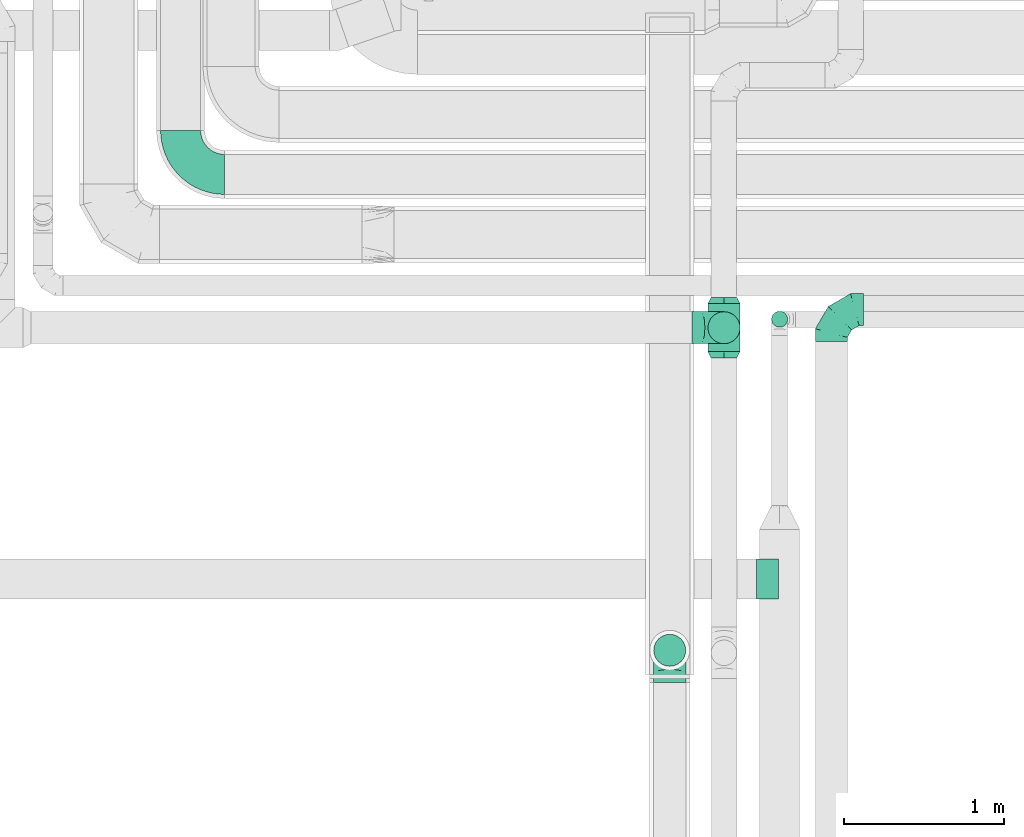
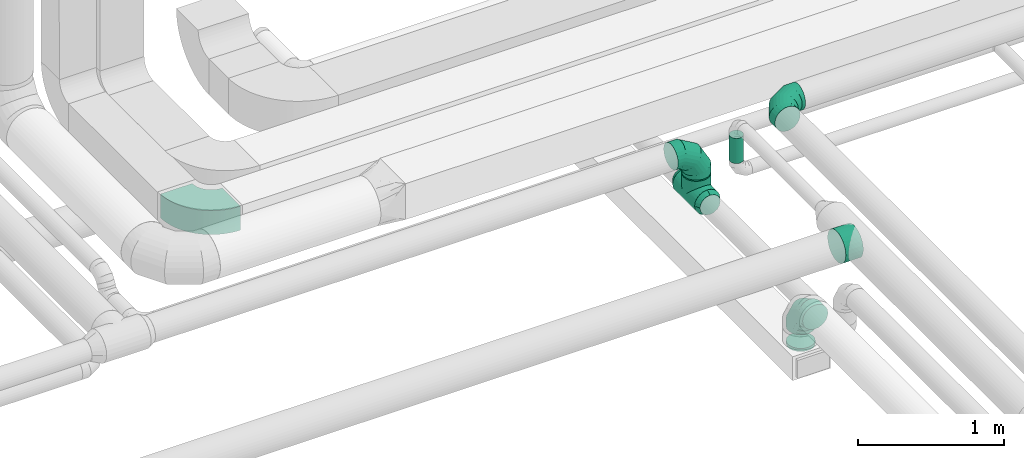
# One storey, part 38 of 92: 9 flow fittings, 2 flow segments.
"""IFC2X3 building model written with IfcOpenShell, lengths in millimetres."""

from ifc_helpers import new_model, entity, si_unit, converted_unit, derived_unit, direction, frame, frame_2d, origin, origin_2d_with_axis, place, context, subcontext, project, spatial, polyline, circle_curve, parameter, trimmed, segment, composite_curve, circle, outline, extrude, faceted_brep, source, transform, mapped, material, type_object, type_shapes, element, save


model = new_model("IFC2X3")

# Units and contexts
model_context = context("Model", 3, precision=0.01, world=origin(), true_north=direction((6.12303176911189e-17, 1.0)))
body_context = subcontext(model_context, "Body", "Model", "MODEL_VIEW")
ifc_project = project(units=[si_unit("LENGTHUNIT", "METRE", prefix="MILLI"), si_unit("AREAUNIT", "SQUARE_METRE"), si_unit("VOLUMEUNIT", "CUBIC_METRE"), converted_unit("PLANEANGLEUNIT", "DEGREE", entity("IfcRatioMeasure", 0.0174532925199433), si_unit("PLANEANGLEUNIT", "RADIAN"), dimensions=[0, 0, 0, 0, 0, 0, 0]), si_unit("MASSUNIT", "GRAM", prefix="KILO"), derived_unit("MASSDENSITYUNIT", [(si_unit("MASSUNIT", "GRAM", prefix="KILO"), 1), (si_unit("LENGTHUNIT", "METRE"), -3)]), derived_unit("MOMENTOFINERTIAUNIT", [(si_unit("LENGTHUNIT", "METRE"), 4)]), si_unit("TIMEUNIT", "SECOND"), si_unit("FREQUENCYUNIT", "HERTZ"), si_unit("THERMODYNAMICTEMPERATUREUNIT", "DEGREE_CELSIUS"), derived_unit("THERMALTRANSMITTANCEUNIT", [(si_unit("MASSUNIT", "GRAM", prefix="KILO"), 1), (si_unit("THERMODYNAMICTEMPERATUREUNIT", "KELVIN"), -1), (si_unit("TIMEUNIT", "SECOND"), -3)]), derived_unit("VOLUMETRICFLOWRATEUNIT", [(si_unit("LENGTHUNIT", "METRE"), 3), (si_unit("TIMEUNIT", "SECOND"), -1)]), derived_unit("MASSFLOWRATEUNIT", [(si_unit("MASSUNIT", "GRAM", prefix="KILO"), 1), (si_unit("TIMEUNIT", "SECOND"), -1)]), derived_unit("ROTATIONALFREQUENCYUNIT", [(si_unit("TIMEUNIT", "SECOND"), -1)]), si_unit("ELECTRICCURRENTUNIT", "AMPERE"), si_unit("ELECTRICVOLTAGEUNIT", "VOLT"), si_unit("POWERUNIT", "WATT"), si_unit("FORCEUNIT", "NEWTON", prefix="KILO"), si_unit("ILLUMINANCEUNIT", "LUX"), si_unit("LUMINOUSFLUXUNIT", "LUMEN"), si_unit("LUMINOUSINTENSITYUNIT", "CANDELA"), derived_unit("USERDEFINED", [(si_unit("MASSUNIT", "GRAM", prefix="KILO"), -1), (si_unit("LENGTHUNIT", "METRE"), -2), (si_unit("TIMEUNIT", "SECOND"), 3), (si_unit("LUMINOUSFLUXUNIT", "LUMEN"), 1)]), derived_unit("LINEARVELOCITYUNIT", [(si_unit("LENGTHUNIT", "METRE"), 1), (si_unit("TIMEUNIT", "SECOND"), -1)]), si_unit("PRESSUREUNIT", "PASCAL"), derived_unit("USERDEFINED", [(si_unit("LENGTHUNIT", "METRE"), -2), (si_unit("MASSUNIT", "GRAM", prefix="KILO"), 1), (si_unit("TIMEUNIT", "SECOND"), -2)]), derived_unit("LINEARFORCEUNIT", [(si_unit("MASSUNIT", "GRAM", prefix="KILO"), 1), (si_unit("LENGTHUNIT", "METRE"), 1), (si_unit("TIMEUNIT", "SECOND"), -2), (si_unit("LENGTHUNIT", "METRE"), -1)]), derived_unit("PLANARFORCEUNIT", [(si_unit("MASSUNIT", "GRAM", prefix="KILO"), 1), (si_unit("LENGTHUNIT", "METRE"), 1), (si_unit("TIMEUNIT", "SECOND"), -2), (si_unit("LENGTHUNIT", "METRE"), -2)])], contexts=[model_context])

# Site, building, storey
site_placement = place(None, origin())
site = spatial("IfcSite", under=ifc_project, at=site_placement, CompositionType="ELEMENT")
building_placement = place(site_placement, origin())
building = spatial("IfcBuilding", under=site, at=building_placement, CompositionType="ELEMENT")
storey_placement = place(building_placement, frame((0.0, 0.0, 4200.0)))
storey = spatial("IfcBuildingStorey", under=building, at=storey_placement, CompositionType="ELEMENT", Elevation=4200.0)

# Flow segments
duct_segment_type_1 = type_object("IfcDuctSegmentType", PredefinedType="NOTDEFINED")
flow_segment_1_placement = place(storey_placement, frame((12738.9, 11238.35, 3050.0)))
element("IfcFlowSegment", 1, at=flow_segment_1_placement, inside=storey, type_object=duct_segment_type_1, context=body_context, shape_type="SweptSolid", body=[
    extrude(circle(Radius=50.0, at=origin_2d_with_axis()), frame((51.6, 51.6, 0.0), z_axis=(0.0, 0.0, 1.0), x_axis=(-1.0, 0.0, 0.0)), (0.0, 0.0, 1.0), 210.000000000015),
])
duct_segment_type_2 = type_object("IfcDuctSegmentType", PredefinedType="NOTDEFINED")
flow_segment_2_placement = place(storey_placement, frame((12341.42, 11135.6, 3090.0)))
element("IfcFlowSegment", 2, at=flow_segment_2_placement, inside=storey, type_object=duct_segment_type_2, context=body_context, shape_type="SweptSolid", body=[
    extrude(circle(Radius=100.0, at=origin_2d_with_axis()), frame((101.6, 101.6, 0.0), z_axis=(0.0, 0.0, 1.0), x_axis=(0.0, 1.0, 0.0)), (0.0, 0.0, 1.0), 10.0000000000248),
])

# Flow fittings
ifc_material = material()
duct_fitting_type_1 = type_object("IfcDuctFittingType", PredefinedType="NOTDEFINED", material=ifc_material)
shared_shape_1 = source(origin(), body_context, "Body", "Brep", [
    faceted_brep([(40.0, -58.78, -80.9), (40.0, -30.9, -95.11), (40.0, 0.0, -100.0), (40.0, 30.9, -95.11), (40.0, 58.78, -80.9), (40.0, 80.9, -58.78), (40.0, 95.11, -30.9), (40.0, 100.0, 0.0), (40.0, 95.11, 30.9), (40.0, 80.9, 58.78), (40.0, 58.78, 80.9), (40.0, 30.9, 95.11), (40.0, 0.0, 100.0), (40.0, -30.9, 95.11), (40.0, -58.78, 80.9), (40.0, -80.9, 58.78), (40.0, -95.11, 30.9), (40.0, -100.0, 0.0), (40.0, -95.11, -30.9), (40.0, -80.9, -58.78), (0.0, -30.61, -73.91), (0.0, -43.59, -65.24), (0.0, -56.57, -56.57), (0.0, -65.24, -43.59), (0.0, -73.91, -30.61), (0.0, -76.96, -15.31), (0.0, -80.0, 0.0), (0.0, -76.96, 15.31), (0.0, -73.91, 30.61), (0.0, -65.24, 43.59), (0.0, -56.57, 56.57), (0.0, -43.59, 65.24), (0.0, -30.61, 73.91), (0.0, -15.31, 76.96), (0.0, 0.0, 80.0), (0.0, 15.31, 76.96), (0.0, 30.61, 73.91), (0.0, 43.59, 65.24), (0.0, 56.57, 56.57), (0.0, 65.24, 43.59), (0.0, 73.91, 30.61), (0.0, 76.96, 15.31), (0.0, 80.0, 0.0), (0.0, 76.96, -15.31), (0.0, 73.91, -30.61), (0.0, 65.24, -43.59), (0.0, 56.57, -56.57), (0.0, 43.59, -65.24), (0.0, 30.61, -73.91), (0.0, 15.31, -76.96), (0.0, 0.0, -80.0), (0.0, -15.31, -76.96)], [[[0, 1, 2, 3, 4, 5, 6, 7, 8, 9, 10, 11, 12, 13, 14, 15, 16, 17, 18, 19]], [[20, 21, 22, 23, 24, 25, 26, 27, 28, 29, 30, 31, 32, 33, 34, 35, 36, 37, 38, 39, 40, 41, 42, 43, 44, 45, 46, 47, 48, 49, 50, 51]], [[7, 41, 8]], [[40, 9, 8]], [[10, 38, 37, 36]], [[39, 38, 9, 40]], [[11, 36, 35]], [[34, 12, 35]], [[41, 40, 8]], [[10, 36, 11]], [[35, 12, 11]], [[41, 7, 42]], [[38, 10, 9]], [[12, 33, 13]], [[32, 14, 13]], [[15, 30, 29, 28]], [[31, 30, 14, 32]], [[16, 28, 27]], [[26, 17, 27]], [[33, 32, 13]], [[15, 28, 16]], [[27, 17, 16]], [[33, 12, 34]], [[30, 15, 14]], [[17, 25, 18]], [[24, 19, 18]], [[0, 22, 21, 20]], [[23, 22, 19, 24]], [[1, 20, 51]], [[50, 2, 51]], [[25, 24, 18]], [[0, 20, 1]], [[51, 2, 1]], [[25, 17, 26]], [[22, 0, 19]], [[2, 49, 3]], [[48, 4, 3]], [[5, 46, 45, 44]], [[47, 46, 4, 48]], [[6, 44, 43]], [[42, 7, 43]], [[49, 48, 3]], [[5, 44, 6]], [[43, 7, 6]], [[49, 2, 50]], [[46, 5, 4]]]),
])
type_shapes(duct_fitting_type_1, [shared_shape_1])
for number, where, z_axis, x_axis in (
    (3, (12443.02, 11427.19, 2940.0), (0.0, 0.0, 1.0), (0.0, -1.0, 0.0)),
    (4, (12443.02, 11047.19, 2940.0), (0.0, 0.0, 1.0), (0.0, 1.0, 0.0)),
):
    element("IfcFlowFitting", number, at=place(storey_placement, frame(where, z_axis=z_axis, x_axis=x_axis)), inside=storey, type_object=duct_fitting_type_1, material=ifc_material, context=body_context, shape_type="MappedRepresentation", body=[
        mapped(shared_shape_1, transform((0.0, 0.0, 0.0), scale=1.0)),
    ])
duct_fitting_type_2 = type_object("IfcDuctFittingType", PredefinedType="NOTDEFINED", material=ifc_material)
shared_shape_2 = source(origin(), body_context, "Body", "Brep", [
    faceted_brep([(-200.0, 0.0, -100.0), (-200.0, -25.88, -96.59), (-200.0, -50.0, -86.6), (-200.0, -70.71, -70.71), (-200.0, -86.6, -50.0), (-200.0, -96.59, -25.88), (-200.0, -100.0, 0.0), (-200.0, -96.59, 25.88), (-200.0, -86.6, 50.0), (-200.0, -70.71, 70.71), (-200.0, -50.0, 86.6), (-200.0, -25.88, 96.59), (-200.0, 0.0, 100.0), (-200.0, 25.88, 96.59), (-200.0, 50.0, 86.6), (-200.0, 70.71, 70.71), (-200.0, 86.6, 50.0), (-200.0, 96.59, 25.88), (-200.0, 100.0, 0.0), (-200.0, 96.59, -25.88), (-200.0, 86.6, -50.0), (-200.0, 70.71, -70.71), (-200.0, 50.0, -86.6), (-200.0, 25.88, -96.59), (-153.35, 25.88, 96.59), (-159.81, 50.0, 86.6), (-146.41, 0.0, 100.0), (-165.36, 70.71, 70.71), (-172.29, 96.59, 25.88), (-173.21, 100.0, 0.0), (-169.62, 86.6, 50.0), (-169.62, 86.6, -50.0), (-165.36, 70.71, -70.71), (-172.29, 96.59, -25.88), (-153.35, 25.88, -96.59), (-146.41, 0.0, -100.0), (-159.81, 50.0, -86.6), (-139.48, -25.88, -96.59), (-133.01, -50.0, -86.6), (-127.46, -70.71, -70.71), (-123.21, -86.6, -50.0), (-120.53, -96.59, -25.88), (-119.62, -100.0, 0.0), (-120.53, -96.59, 25.88), (-123.21, -86.6, 50.0), (-127.46, -70.71, 70.71), (-133.01, -50.0, 86.6), (-139.48, -25.88, 96.59), (-72.54, 72.54, 96.59), (-90.19, 90.19, 86.6), (-53.59, 53.59, 100.0), (-105.35, 105.35, 70.71), (-116.99, 116.99, 50.0), (-124.3, 124.3, 25.88), (-126.79, 126.79, 0.0), (-124.3, 124.3, -25.88), (-116.99, 116.99, -50.0), (-105.35, 105.35, -70.71), (-72.54, 72.54, -96.59), (-53.59, 53.59, -100.0), (-90.19, 90.19, -86.6), (-34.64, 34.64, -96.59), (-16.99, 16.99, -86.6), (-1.83, 1.83, -70.71), (9.81, -9.81, -50.0), (17.12, -17.12, -25.88), (19.62, -19.62, 0.0), (17.12, -17.12, 25.88), (9.81, -9.81, 50.0), (-1.83, 1.83, 70.71), (-16.99, 16.99, 86.6), (-34.64, 34.64, 96.59), (-25.88, 153.35, 96.59), (-50.0, 159.81, 86.6), (0.0, 146.41, 100.0), (-70.71, 165.36, 70.71), (-86.6, 169.62, 50.0), (-96.59, 172.29, 25.88), (-100.0, 173.21, 0.0), (-96.59, 172.29, -25.88), (-86.6, 169.62, -50.0), (-70.71, 165.36, -70.71), (-25.88, 153.35, -96.59), (0.0, 146.41, -100.0), (-50.0, 159.81, -86.6), (25.88, 139.48, -96.59), (50.0, 133.01, -86.6), (70.71, 127.46, -70.71), (86.6, 123.21, -50.0), (96.59, 120.53, -25.88), (100.0, 119.62, 0.0), (96.59, 120.53, 25.88), (86.6, 123.21, 50.0), (70.71, 127.46, 70.71), (50.0, 133.01, 86.6), (25.88, 139.48, 96.59), (-25.88, 200.0, -96.59), (-50.0, 200.0, -86.6), (-70.71, 200.0, -70.71), (-86.6, 200.0, -50.0), (-96.59, 200.0, -25.88), (-100.0, 200.0, 0.0), (-96.59, 200.0, 25.88), (-86.6, 200.0, 50.0), (-70.71, 200.0, 70.71), (-50.0, 200.0, 86.6), (-25.88, 200.0, 96.59), (0.0, 200.0, 100.0), (25.88, 200.0, 96.59), (50.0, 200.0, 86.6), (70.71, 200.0, 70.71), (86.6, 200.0, 50.0), (96.59, 200.0, 25.88), (100.0, 200.0, 0.0), (96.59, 200.0, -25.88), (86.6, 200.0, -50.0), (70.71, 200.0, -70.71), (50.0, 200.0, -86.6), (25.88, 200.0, -96.59), (0.0, 200.0, -100.0)], [[[0, 1, 2, 3, 4, 5, 6, 7, 8, 9, 10, 11, 12, 13, 14, 15, 16, 17, 18, 19, 20, 21, 22, 23]], [[24, 25, 14, 13]], [[26, 24, 13, 12]], [[14, 25, 27, 15]], [[28, 29, 18, 17]], [[30, 28, 17, 16]], [[15, 27, 30, 16]], [[20, 31, 32, 21]], [[33, 31, 20, 19]], [[18, 29, 33, 19]], [[34, 35, 0, 23]], [[36, 34, 23, 22]], [[32, 36, 22, 21]], [[1, 0, 35, 37]], [[2, 1, 37, 38]], [[38, 39, 3, 2]], [[5, 4, 40, 41]], [[6, 5, 41, 42]], [[39, 40, 4, 3]], [[6, 42, 43, 7]], [[7, 43, 44, 8]], [[8, 44, 45, 9]], [[9, 45, 46, 10]], [[10, 46, 47, 11]], [[26, 12, 11, 47]], [[48, 49, 25, 24]], [[50, 48, 24, 26]], [[27, 25, 49, 51]], [[52, 53, 28, 30]], [[51, 52, 30, 27]], [[29, 28, 53, 54]], [[55, 56, 31, 33]], [[54, 55, 33, 29]], [[32, 31, 56, 57]], [[58, 59, 35, 34]], [[60, 58, 34, 36]], [[57, 60, 36, 32]], [[37, 35, 59, 61]], [[38, 37, 61, 62]], [[39, 38, 62, 63]], [[41, 40, 64, 65]], [[42, 41, 65, 66]], [[63, 64, 40, 39]], [[43, 42, 66, 67]], [[44, 43, 67, 68]], [[68, 69, 45, 44]], [[46, 45, 69, 70]], [[47, 46, 70, 71]], [[26, 47, 71, 50]], [[72, 73, 49, 48]], [[74, 72, 48, 50]], [[51, 49, 73, 75]], [[76, 77, 53, 52]], [[75, 76, 52, 51]], [[54, 53, 77, 78]], [[79, 80, 56, 55]], [[78, 79, 55, 54]], [[57, 56, 80, 81]], [[82, 83, 59, 58]], [[84, 82, 58, 60]], [[81, 84, 60, 57]], [[61, 59, 83, 85]], [[62, 61, 85, 86]], [[63, 62, 86, 87]], [[65, 64, 88, 89]], [[66, 65, 89, 90]], [[87, 88, 64, 63]], [[67, 66, 90, 91]], [[68, 67, 91, 92]], [[92, 93, 69, 68]], [[70, 69, 93, 94]], [[71, 70, 94, 95]], [[50, 71, 95, 74]], [[96, 97, 98, 99, 100, 101, 102, 103, 104, 105, 106, 107, 108, 109, 110, 111, 112, 113, 114, 115, 116, 117, 118, 119]], [[72, 74, 107, 106]], [[73, 72, 106, 105]], [[75, 73, 105, 104]], [[102, 101, 78, 77]], [[103, 102, 77, 76]], [[75, 104, 103, 76]], [[78, 101, 100, 79]], [[79, 100, 99, 80]], [[80, 99, 98, 81]], [[84, 97, 96, 82]], [[82, 96, 119, 83]], [[84, 81, 98, 97]], [[118, 117, 86, 85]], [[119, 118, 85, 83]], [[116, 87, 86, 117]], [[88, 115, 114, 89]], [[89, 114, 113, 90]], [[115, 88, 87, 116]], [[91, 90, 113, 112]], [[92, 91, 112, 111]], [[111, 110, 93, 92]], [[95, 94, 109, 108]], [[74, 95, 108, 107]], [[110, 109, 94, 93]]]),
])
type_shapes(duct_fitting_type_2, [shared_shape_2])
for number, where, z_axis, x_axis in (
    (5, (13113.91, 11349.98, 3360.0), (0.0, 0.0, 1.0), (-1.0, 0.0, 0.0)),
    (6, (12443.02, 11237.19, 3300.0), (0.0, -1.0, 0.0), (0.0, 0.0, 1.0)),
    (7, (12104.27, 9222.49, 3350.0), (-1.0, 0.0, 0.0), (0.0, 1.0, 0.0)),
):
    element("IfcFlowFitting", number, at=place(storey_placement, frame(where, z_axis=z_axis, x_axis=x_axis)), inside=storey, type_object=duct_fitting_type_2, material=ifc_material, context=body_context, shape_type="MappedRepresentation", body=[
        mapped(shared_shape_2, transform((0.0, 0.0, 0.0), scale=1.0)),
    ])
duct_fitting_type_3 = type_object("IfcDuctFittingType", PredefinedType="NOTDEFINED", material=ifc_material)
shared_shape_3 = source(origin(), body_context, "Body", "Brep", [
    faceted_brep([(20.0, 0.0, -100.0), (20.0, 25.88, -96.59), (20.0, 50.0, -86.6), (20.0, 70.71, -70.71), (20.0, 86.6, -50.0), (20.0, 96.59, -25.88), (20.0, 100.0, 0.0), (20.0, 96.59, 25.88), (20.0, 86.6, 50.0), (20.0, 70.71, 70.71), (20.0, 50.0, 86.6), (20.0, 25.88, 96.59), (20.0, 0.0, 100.0), (20.0, -25.88, 96.59), (20.0, -50.0, 86.6), (20.0, -70.71, 70.71), (20.0, -86.6, 50.0), (20.0, -96.59, 25.88), (20.0, -100.0, 0.0), (20.0, -96.59, -25.88), (20.0, -86.6, -50.0), (20.0, -70.71, -70.71), (20.0, -50.0, -86.6), (20.0, -25.88, -96.59), (0.0, 0.0, 100.0), (-6.1, 0.0, 100.0), (-6.1, -25.88, 96.59), (0.0, -25.88, 96.59), (-6.1, -50.0, 86.6), (0.0, -50.0, 86.6), (0.0, -70.71, 70.71), (-6.1, -70.71, 70.71), (0.0, -86.6, 50.0), (-6.1, -86.6, 50.0), (-6.1, -96.59, 25.88), (0.0, -96.59, 25.88), (-6.1, -100.0, 0.0), (0.0, -100.0, 0.0), (-6.1, -96.59, -25.88), (0.0, -96.59, -25.88), (-6.1, -86.6, -50.0), (0.0, -86.6, -50.0), (0.0, -70.71, -70.71), (-6.1, -70.71, -70.71), (0.0, -50.0, -86.6), (-6.1, -50.0, -86.6), (-6.1, -25.88, -96.59), (0.0, -25.88, -96.59), (-6.1, 0.0, -100.0), (0.0, 0.0, -100.0), (-6.1, 25.88, -96.59), (0.0, 25.88, -96.59), (-6.1, 50.0, -86.6), (0.0, 50.0, -86.6), (0.0, 70.71, -70.71), (-6.1, 70.71, -70.71), (0.0, 86.6, -50.0), (-6.1, 86.6, -50.0), (-6.1, 96.59, -25.88), (0.0, 96.59, -25.88), (-6.1, 100.0, 0.0), (0.0, 100.0, 0.0), (-6.1, 96.59, 25.88), (0.0, 96.59, 25.88), (-6.1, 86.6, 50.0), (0.0, 86.6, 50.0), (0.0, 70.71, 70.71), (-6.1, 70.71, 70.71), (0.0, 50.0, 86.6), (-6.1, 50.0, 86.6), (-6.1, 25.88, 96.59), (0.0, 25.88, 96.59)], [[[0, 1, 2, 3, 4, 5, 6, 7, 8, 9, 10, 11, 12, 13, 14, 15, 16, 17, 18, 19, 20, 21, 22, 23]], [[13, 12, 24, 25, 26, 27]], [[14, 13, 27, 26, 28, 29]], [[30, 15, 14, 29, 28, 31]], [[17, 16, 32, 33, 34, 35]], [[18, 17, 35, 34, 36, 37]], [[32, 16, 15, 30, 31, 33]], [[19, 18, 37, 36, 38, 39]], [[20, 19, 39, 38, 40, 41]], [[42, 21, 20, 41, 40, 43]], [[23, 22, 44, 45, 46, 47]], [[0, 23, 47, 46, 48, 49]], [[44, 22, 21, 42, 43, 45]], [[1, 0, 49, 48, 50, 51]], [[2, 1, 51, 50, 52, 53]], [[54, 3, 2, 53, 52, 55]], [[5, 4, 56, 57, 58, 59]], [[6, 5, 59, 58, 60, 61]], [[56, 4, 3, 54, 55, 57]], [[7, 6, 61, 60, 62, 63]], [[8, 7, 63, 62, 64, 65]], [[66, 9, 8, 65, 64, 67]], [[11, 10, 68, 69, 70, 71]], [[12, 11, 71, 70, 25, 24]], [[68, 10, 9, 66, 67, 69]], [[46, 45, 43, 40, 38, 36, 34, 33, 31, 28, 26, 25, 70, 69, 67, 64, 62, 60, 58, 57, 55, 52, 50, 48]]]),
])
type_shapes(duct_fitting_type_3, [shared_shape_3])
flow_fitting_1_placement = place(storey_placement, frame((12104.27, 9222.49, 3015.0), z_axis=(0.0, 1.0, 0.0), x_axis=(0.0, 0.0, 1.0)))
element("IfcFlowFitting", 8, at=flow_fitting_1_placement, inside=storey, type_object=duct_fitting_type_3, material=ifc_material, context=body_context, shape_type="MappedRepresentation", body=[
    mapped(shared_shape_3, transform((0.0, 0.0, 0.0), scale=1.0)),
])
duct_fitting_type_4 = type_object("IfcDuctFittingType", PredefinedType="NOTDEFINED", material=ifc_material)
shared_shape_4 = source(origin(), body_context, "Body", "Brep", [
    faceted_brep([(14.97, -14.97, -98.87), (150.0, 0.0, -100.0), (150.0, -25.88, -96.59), (150.0, -50.0, -86.6), (44.19, -44.19, -89.71), (58.0, -58.0, -81.46), (150.0, -70.71, -70.71), (0.0, 0.0, -100.0), (-14.97, -14.97, -98.87), (-150.0, 0.0, -100.0), (29.76, -29.76, -95.47), (82.28, -82.28, -56.83), (150.0, -86.6, -50.0), (91.56, -91.56, -40.2), (150.0, -96.59, -25.88), (97.79, -97.79, -20.93), (150.0, -100.0, 0.0), (70.86, -70.86, -70.56), (100.0, -100.0, 0.0), (-150.0, -100.0, 0.0), (-97.79, -97.79, -20.93), (-100.0, -100.0, 0.0), (97.79, -97.79, 20.93), (-97.79, -97.79, 20.93), (150.0, -96.59, 25.88), (91.56, -91.56, 40.2), (150.0, -86.6, 50.0), (150.0, -70.71, 70.71), (70.86, -70.86, 70.56), (82.28, -82.28, 56.83), (58.0, -58.0, 81.46), (150.0, -50.0, 86.6), (44.19, -44.19, 89.71), (150.0, -25.88, 96.59), (14.97, -14.97, 98.87), (150.0, 0.0, 100.0), (29.76, -29.76, 95.47), (0.0, 0.0, 100.0), (-14.97, -14.97, 98.87), (-150.0, 0.0, 100.0), (25.88, -150.0, -96.59), (50.0, -150.0, -86.6), (70.71, -150.0, -70.71), (86.6, -150.0, -50.0), (96.59, -150.0, -25.88), (100.0, -150.0, 0.0), (96.59, -150.0, 25.88), (86.6, -150.0, 50.0), (70.71, -150.0, 70.71), (50.0, -150.0, 86.6), (25.88, -150.0, 96.59), (0.0, -150.0, 100.0), (-25.88, -150.0, 96.59), (-50.0, -150.0, 86.6), (-70.71, -150.0, 70.71), (-86.6, -150.0, 50.0), (-96.59, -150.0, 25.88), (-100.0, -150.0, 0.0), (-96.59, -150.0, -25.88), (-86.6, -150.0, -50.0), (-70.71, -150.0, -70.71), (-50.0, -150.0, -86.6), (-25.88, -150.0, -96.59), (0.0, -150.0, -100.0), (-44.19, -44.19, -89.71), (-58.0, -58.0, -81.46), (-29.76, -29.76, -95.47), (-82.28, -82.28, -56.83), (-91.56, -91.56, -40.2), (-70.86, -70.86, -70.56), (-91.56, -91.56, 40.2), (-70.86, -70.86, 70.56), (-82.28, -82.28, 56.83), (-58.0, -58.0, 81.46), (-44.19, -44.19, 89.71), (-29.76, -29.76, 95.47), (-150.0, -25.88, -96.59), (-150.0, -50.0, -86.6), (-150.0, -70.71, -70.71), (-150.0, -86.6, -50.0), (-150.0, -96.59, -25.88), (-150.0, -96.59, 25.88), (-150.0, -86.6, 50.0), (-150.0, -70.71, 70.71), (-150.0, -50.0, 86.6), (-150.0, -25.88, 96.59), (-150.0, 25.88, 96.59), (-150.0, 50.0, 86.6), (-150.0, 70.71, 70.71), (-150.0, 86.6, 50.0), (-150.0, 96.59, 25.88), (-150.0, 100.0, 0.0), (-150.0, 96.59, -25.88), (-150.0, 86.6, -50.0), (-150.0, 70.71, -70.71), (-150.0, 50.0, -86.6), (-150.0, 25.88, -96.59), (150.0, 25.88, -96.59), (150.0, 50.0, -86.6), (150.0, 70.71, -70.71), (150.0, 86.6, -50.0), (150.0, 96.59, -25.88), (150.0, 100.0, 0.0), (150.0, 96.59, 25.88), (150.0, 86.6, 50.0), (150.0, 70.71, 70.71), (150.0, 50.0, 86.6), (150.0, 25.88, 96.59)], [[[0, 1, 2]], [[2, 3, 4]], [[5, 3, 6]], [[5, 4, 3]], [[0, 7, 1]], [[7, 8, 9]], [[4, 10, 2]], [[0, 2, 10]], [[11, 6, 12]], [[13, 12, 14]], [[15, 14, 16]], [[11, 17, 6]], [[15, 13, 14]], [[18, 15, 16]], [[19, 20, 21]], [[11, 12, 13]], [[6, 17, 5]], [[22, 18, 16]], [[21, 23, 19]], [[22, 16, 24]], [[25, 24, 26]], [[25, 22, 24]], [[27, 28, 29]], [[25, 26, 29]], [[29, 26, 27]], [[30, 27, 31]], [[32, 31, 33]], [[34, 33, 35]], [[32, 30, 31]], [[34, 36, 33]], [[37, 34, 35]], [[38, 37, 39]], [[32, 33, 36]], [[27, 30, 28]], [[40, 41, 42, 43, 44, 45, 46, 47, 48, 49, 50, 51, 52, 53, 54, 55, 56, 57, 58, 59, 60, 61, 62, 63]], [[34, 51, 50]], [[50, 49, 32]], [[30, 49, 48]], [[30, 32, 49]], [[34, 37, 51]], [[32, 36, 50]], [[34, 50, 36]], [[29, 48, 47]], [[25, 47, 46]], [[22, 46, 45]], [[29, 28, 48]], [[22, 25, 46]], [[18, 22, 45]], [[29, 47, 25]], [[48, 28, 30]], [[15, 18, 45]], [[15, 45, 44]], [[13, 44, 43]], [[13, 15, 44]], [[42, 17, 11]], [[13, 43, 11]], [[11, 43, 42]], [[5, 42, 41]], [[4, 41, 40]], [[0, 40, 63]], [[4, 5, 41]], [[0, 10, 40]], [[7, 0, 63]], [[4, 40, 10]], [[42, 5, 17]], [[8, 63, 62]], [[62, 61, 64]], [[65, 61, 60]], [[65, 64, 61]], [[8, 7, 63]], [[64, 66, 62]], [[8, 62, 66]], [[67, 60, 59]], [[68, 59, 58]], [[20, 58, 57]], [[67, 69, 60]], [[20, 68, 58]], [[21, 20, 57]], [[67, 59, 68]], [[60, 69, 65]], [[23, 21, 57]], [[23, 57, 56]], [[70, 56, 55]], [[70, 23, 56]], [[54, 71, 72]], [[70, 55, 72]], [[72, 55, 54]], [[73, 54, 53]], [[74, 53, 52]], [[38, 52, 51]], [[74, 73, 53]], [[38, 75, 52]], [[37, 38, 51]], [[74, 52, 75]], [[54, 73, 71]], [[9, 76, 77, 78, 79, 80, 19, 81, 82, 83, 84, 85, 39, 86, 87, 88, 89, 90, 91, 92, 93, 94, 95, 96]], [[97, 98, 99, 100, 101, 102, 103, 104, 105, 106, 107, 35, 33, 31, 27, 26, 24, 16, 14, 12, 6, 3, 2, 1]], [[37, 35, 107, 86, 39]], [[87, 86, 107, 106]], [[106, 105, 88, 87]], [[89, 88, 105, 104]], [[90, 89, 104, 103]], [[91, 90, 103, 102]], [[92, 91, 102, 101]], [[93, 92, 101, 100]], [[100, 99, 94, 93]], [[95, 94, 99, 98]], [[96, 95, 98, 97]], [[7, 9, 96, 97, 1]], [[66, 64, 76]], [[8, 66, 76]], [[9, 8, 76]], [[77, 65, 78]], [[77, 76, 64]], [[65, 77, 64]], [[69, 67, 78]], [[68, 20, 80]], [[67, 68, 79]], [[78, 67, 79]], [[20, 19, 80]], [[80, 79, 68]], [[69, 78, 65]], [[23, 70, 81]], [[82, 72, 83]], [[70, 72, 82]], [[19, 23, 81]], [[70, 82, 81]], [[72, 71, 83]], [[74, 75, 85]], [[75, 38, 85]], [[83, 73, 84]], [[73, 83, 71]], [[74, 84, 73]], [[74, 85, 84]], [[38, 39, 85]]]),
])
type_shapes(duct_fitting_type_4, [shared_shape_4])
flow_fitting_2_placement = place(storey_placement, frame((12443.02, 11237.19, 2940.0), z_axis=(1.0, 0.0, 0.0), x_axis=(0.0, -1.0, 0.0)))
element("IfcFlowFitting", 9, at=flow_fitting_2_placement, inside=storey, type_object=duct_fitting_type_4, material=ifc_material, context=body_context, shape_type="MappedRepresentation", body=[
    mapped(shared_shape_4, transform((0.0, 0.0, 0.0), scale=1.0)),
])
duct_fitting_type_5 = type_object("IfcDuctFittingType", PredefinedType="NOTDEFINED", material=ifc_material)
shared_shape_5 = source(origin(), body_context, "Body", "Brep", [
    faceted_brep([(20.0, 32.35, -120.74), (20.0, 62.5, -108.25), (20.0, 88.39, -88.39), (20.0, 108.25, -62.5), (20.0, 120.74, -32.35), (20.0, 125.0, 0.0), (20.0, 120.74, 32.35), (20.0, 108.25, 62.5), (20.0, 88.39, 88.39), (20.0, 62.5, 108.25), (20.0, 32.35, 120.74), (20.0, 0.0, 125.0), (20.0, -32.35, 120.74), (20.0, -62.5, 108.25), (20.0, -88.39, 88.39), (20.0, -108.25, 62.5), (20.0, -120.74, 32.35), (20.0, -125.0, 0.0), (20.0, -120.74, -32.35), (20.0, -108.25, -62.5), (20.0, -88.39, -88.39), (20.0, -62.5, -108.25), (20.0, -32.35, -120.74), (20.0, 0.0, -125.0), (0.0, 0.0, 125.0), (0.0, 32.35, 120.74), (-118.9, 32.35, 120.74), (-118.9, 0.0, 125.0), (0.0, 62.5, 108.25), (-118.9, 62.5, 108.25), (0.0, 88.39, 88.39), (-118.9, 88.39, 88.39), (0.0, 108.25, 62.5), (0.0, 120.74, 32.35), (-118.9, 120.74, 32.35), (-118.9, 108.25, 62.5), (0.0, 125.0, 0.0), (-118.9, 125.0, 0.0), (0.0, 120.74, -32.35), (-118.9, 120.74, -32.35), (0.0, 108.25, -62.5), (-118.9, 108.25, -62.5), (0.0, 88.39, -88.39), (-118.9, 88.39, -88.39), (0.0, 62.5, -108.25), (0.0, 32.35, -120.74), (-118.9, 32.35, -120.74), (-118.9, 62.5, -108.25), (0.0, 0.0, -125.0), (-118.9, 0.0, -125.0), (0.0, -32.35, -120.74), (-118.9, -32.35, -120.74), (0.0, -62.5, -108.25), (-118.9, -62.5, -108.25), (0.0, -88.39, -88.39), (-118.9, -88.39, -88.39), (0.0, -108.25, -62.5), (0.0, -120.74, -32.35), (-118.9, -120.74, -32.35), (-118.9, -108.25, -62.5), (0.0, -125.0, 0.0), (-118.9, -125.0, 0.0), (0.0, -120.74, 32.35), (-118.9, -120.74, 32.35), (0.0, -108.25, 62.5), (-118.9, -108.25, 62.5), (0.0, -88.39, 88.39), (-118.9, -88.39, 88.39), (0.0, -62.5, 108.25), (0.0, -32.35, 120.74), (-118.9, -32.35, 120.74), (-118.9, -62.5, 108.25)], [[[0, 1, 2, 3, 4, 5, 6, 7, 8, 9, 10, 11, 12, 13, 14, 15, 16, 17, 18, 19, 20, 21, 22, 23]], [[24, 11, 10, 25, 26, 27]], [[25, 10, 9, 28, 29, 26]], [[28, 9, 8, 30, 31, 29]], [[32, 7, 6, 33, 34, 35]], [[33, 6, 5, 36, 37, 34]], [[30, 8, 7, 32, 35, 31]], [[36, 5, 4, 38, 39, 37]], [[38, 4, 3, 40, 41, 39]], [[40, 3, 2, 42, 43, 41]], [[44, 1, 0, 45, 46, 47]], [[45, 0, 23, 48, 49, 46]], [[42, 2, 1, 44, 47, 43]], [[48, 23, 22, 50, 51, 49]], [[50, 22, 21, 52, 53, 51]], [[52, 21, 20, 54, 55, 53]], [[56, 19, 18, 57, 58, 59]], [[57, 18, 17, 60, 61, 58]], [[54, 20, 19, 56, 59, 55]], [[60, 17, 16, 62, 63, 61]], [[62, 16, 15, 64, 65, 63]], [[64, 15, 14, 66, 67, 65]], [[68, 13, 12, 69, 70, 71]], [[69, 12, 11, 24, 27, 70]], [[66, 14, 13, 68, 71, 67]], [[49, 51, 53, 55, 59, 58, 61, 63, 65, 67, 71, 70, 27, 26, 29, 31, 35, 34, 37, 39, 41, 43, 47, 46]]]),
])
type_shapes(duct_fitting_type_5, [shared_shape_5])
flow_fitting_3_placement = place(storey_placement, frame((12665.5, 9667.14, 3360.0), z_axis=(0.0, 0.0, -1.0), x_axis=(-1.0, 0.0, 0.0)))
element("IfcFlowFitting", 10, at=flow_fitting_3_placement, inside=storey, type_object=duct_fitting_type_5, material=ifc_material, context=body_context, shape_type="MappedRepresentation", body=[
    mapped(shared_shape_5, transform((0.0, 0.0, 0.0), scale=1.0)),
])
duct_fitting_type_6 = type_object("IfcDuctFittingType", PredefinedType="NOTDEFINED", material=ifc_material)
shared_shape_6 = source(origin(), body_context, "Body", "SweptSolid", [
    extrude(outline(composite_curve([segment(polyline([(-262.5, -137.5), (-12.5, -137.5)]), True, "CONTINUOUS"), segment(trimmed(circle_curve(frame_2d((137.5, -137.5), x_axis=(0.0, 1.0)), 150.0), [parameter(0.0)], [parameter(90.0000000000001)], True, "PARAMETER"), False, "CONTINUOUS"), segment(polyline([(137.5, 12.5), (137.5, 262.5)]), True, "CONTINUOUS"), segment(trimmed(circle_curve(frame_2d((137.5, -137.5), x_axis=(0.0, 1.0)), 400.0), [parameter(0.0)], [parameter(90.0000000000001)], True, "PARAMETER"), True, "CONTINUOUS")], self_intersect=False)), frame((-137.5, 137.5, -100.0), z_axis=(0.0, 0.0, 1.0), x_axis=(-1.0, 0.0, 0.0)), (0.0, 0.0, 1.0), 200.0),
])
type_shapes(duct_fitting_type_6, [shared_shape_6])
flow_fitting_4_placement = place(storey_placement, frame((9049.12, 12194.64, 3300.0), z_axis=(0.0, 0.0, 1.0), x_axis=(0.0, -1.0, 0.0)))
element("IfcFlowFitting", 11, at=flow_fitting_4_placement, inside=storey, type_object=duct_fitting_type_6, material=ifc_material, context=body_context, shape_type="MappedRepresentation", body=[
    mapped(shared_shape_6, transform((0.0, 0.0, 0.0), scale=1.0)),
])

save(model, "model.ifc")
